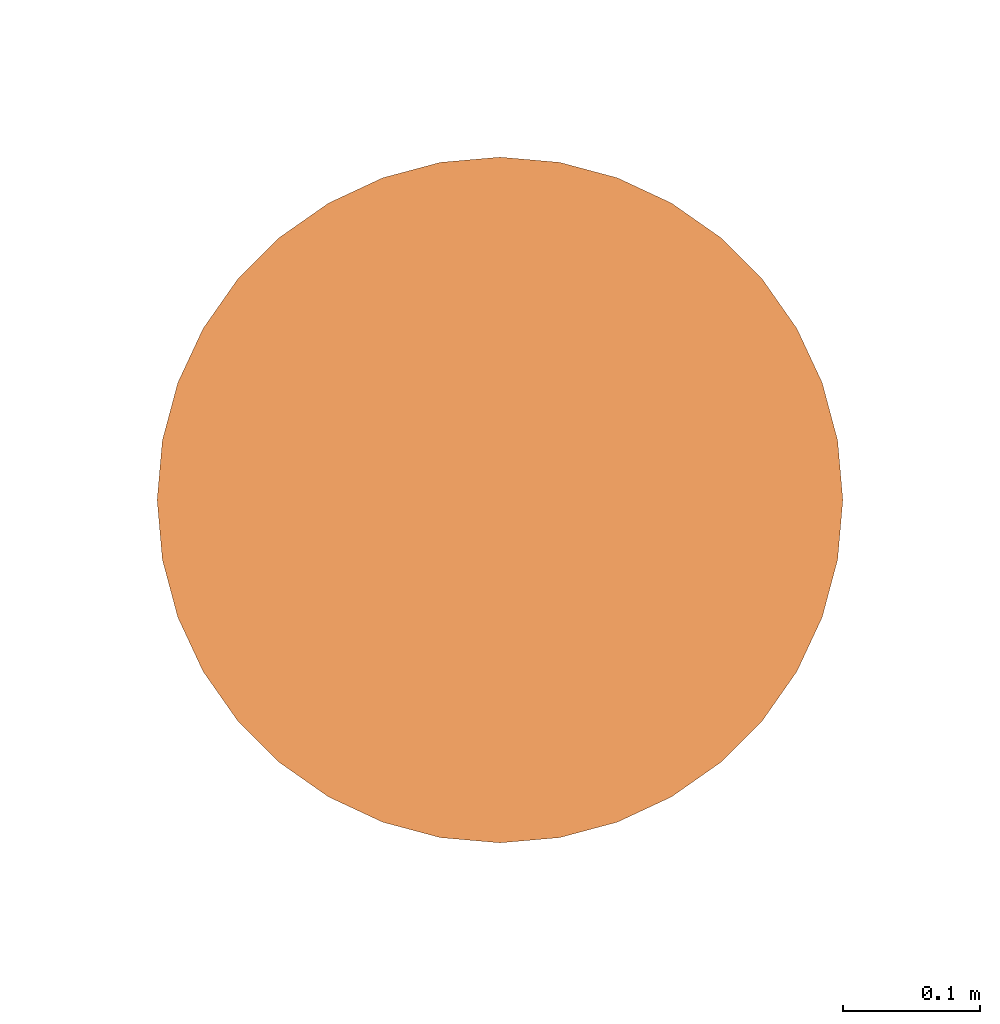
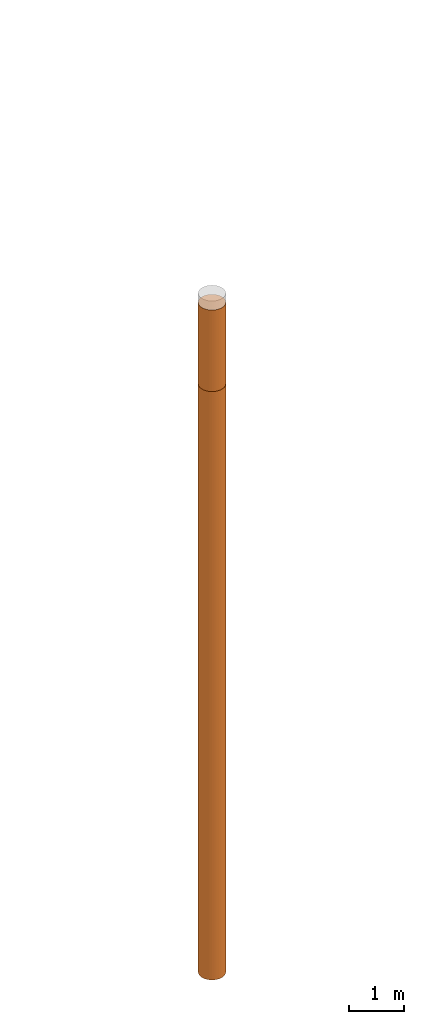
# One storey, part 1 of 8: 2 proxies.
"""IFC4 building model written with IfcOpenShell, lengths in metres."""

from ifc_helpers import new_model, entity, si_unit, converted_unit, frame, origin, place, context, subcontext, project, spatial, faceted_brep, material, element, save


model = new_model("IFC4")

# Units and contexts
model_context = context("Model", 3, precision=1e-05, world=origin())
body_context = subcontext(model_context, "Body", "Model", "MODEL_VIEW")
ifc_project = project(units=[si_unit("LENGTHUNIT", "METRE"), si_unit("AREAUNIT", "SQUARE_METRE"), si_unit("VOLUMEUNIT", "CUBIC_METRE"), converted_unit("PLANEANGLEUNIT", "DEGREE", entity("IfcPlaneAngleMeasure", 0.0174532925199433), si_unit("PLANEANGLEUNIT", "RADIAN"), dimensions=[0, 0, 0, 0, 0, 0, 0])], contexts=[model_context])

# Site, building, storey
site_placement = place(None, origin())
site = spatial("IfcSite", under=ifc_project, at=site_placement, CompositionType="ELEMENT")
building_placement = place(site_placement, origin())
building = spatial("IfcBuilding", under=site, at=building_placement, Name="Demo", CompositionType="ELEMENT")
storey_placement = place(building_placement, origin())
storey = spatial("IfcBuildingStorey", under=building, at=storey_placement, Name="Boden", CompositionType="ELEMENT", Elevation=0.0)

# Proxies
ifc_material_1 = material()
proxy_1_placement = place(storey_placement, frame((2.57, 5.87, -1.9)))
element("IfcBuildingElementProxy", 1, at=proxy_1_placement, inside=storey, material=ifc_material_1, Name="KB-01_Sand", PredefinedType="USERDEFINED", context=body_context, shape_type="Brep", body=[
    faceted_brep([(0.4962019382530516, 0.2934120444167338, 1.8), (0.5, 0.25, 1.8), (0.496201938253052, 0.2065879555832671, 1.8), (0.4849231551964772, 0.1644949641685826, 1.8), (0.4665063509461097, 0.125, 1.8), (0.4415111107797448, 0.08930309757836494, 1.8), (0.4106969024216351, 0.05848888922025526, 1.8), (0.375, 0.0334936490538903, 1.8), (0.3355050358314174, 0.01507684480352327, 1.8), (0.2934120444167325, 0.003798061746948406, 1.8), (0.25, 0.0, 1.8), (0.2065879555832676, 0.003798061746948406, 1.8), (0.164494964168583, 0.01507684480352327, 1.8), (0.125, 0.0334936490538903, 1.8), (0.0893030975783654, 0.05848888922025526, 1.8), (0.05848888922025572, 0.08930309757836494, 1.8), (0.0334936490538903, 0.125, 1.8), (0.01507684480352327, 0.1644949641685826, 1.8), (0.003798061746947951, 0.2065879555832671, 1.8), (0.0, 0.25, 1.8), (0.003798061746947951, 0.293412044416732, 1.8), (0.01507684480352282, 0.3355050358314166, 1.8), (0.03349364905388984, 0.375, 1.8), (0.05848888922025526, 0.4106969024216342, 1.8), (0.08930309757836494, 0.4415111107797439, 1.8), (0.1249999999999995, 0.4665063509461097, 1.8), (0.1644949641685821, 0.4849231551964767, 1.8), (0.2065879555832667, 0.4962019382530516, 1.8), (0.2499999999999991, 0.5, 1.8), (0.293412044416732, 0.4962019382530525, 1.8), (0.3355050358314166, 0.4849231551964777, 1.8), (0.3749999999999991, 0.4665063509461097, 1.8), (0.4106969024216342, 0.4415111107797448, 1.8), (0.4415111107797439, 0.410696902421636, 1.8), (0.4665063509461093, 0.3750000000000009, 1.8), (0.4849231551964767, 0.3355050358314184, 1.8), (0.5, 0.25, 0.0), (0.4962019382530516, 0.2934120444167338, 0.0), (0.4849231551964767, 0.3355050358314184, 0.0), (0.4665063509461093, 0.3750000000000009, 0.0), (0.4415111107797439, 0.4106969024216351, 0.0), (0.4106969024216342, 0.4415111107797448, 0.0), (0.3749999999999991, 0.4665063509461097, 0.0), (0.3355050358314166, 0.4849231551964767, 0.0), (0.293412044416732, 0.4962019382530516, 0.0), (0.2499999999999991, 0.5, 0.0), (0.2065879555832667, 0.4962019382530516, 0.0), (0.1644949641685821, 0.4849231551964767, 0.0), (0.1249999999999995, 0.4665063509461088, 0.0), (0.08930309757836494, 0.4415111107797439, 0.0), (0.05848888922025526, 0.4106969024216342, 0.0), (0.03349364905388984, 0.3749999999999991, 0.0), (0.01507684480352282, 0.3355050358314166, 0.0), (0.003798061746947951, 0.293412044416732, 0.0), (0.0, 0.2499999999999991, 0.0), (0.003798061746947951, 0.2065879555832671, 0.0), (0.01507684480352327, 0.1644949641685826, 0.0), (0.0334936490538903, 0.125, 0.0), (0.05848888922025572, 0.08930309757836494, 0.0), (0.0893030975783654, 0.05848888922025526, 0.0), (0.125, 0.0334936490538903, 0.0), (0.164494964168583, 0.01507684480352236, 0.0), (0.2065879555832676, 0.003798061746947497, 0.0), (0.25, 0.0, 0.0), (0.2934120444167325, 0.003798061746947497, 0.0), (0.3355050358314174, 0.01507684480352236, 0.0), (0.375, 0.0334936490538903, 0.0), (0.4106969024216351, 0.05848888922025526, 0.0), (0.4415111107797448, 0.08930309757836494, 0.0), (0.4665063509461097, 0.125, 0.0), (0.4849231551964772, 0.1644949641685826, 0.0), (0.496201938253052, 0.2065879555832671, 0.0), (0.5, 0.25, 1.8), (0.4962019382530516, 0.2934120444167338, 1.8), (0.4962019382530516, 0.2934120444167338, 0.0), (0.5, 0.25, 0.0), (0.496201938253052, 0.2065879555832671, 1.8), (0.5, 0.25, 1.8), (0.5, 0.25, 0.0), (0.496201938253052, 0.2065879555832671, 0.0), (0.4849231551964772, 0.1644949641685826, 1.8), (0.496201938253052, 0.2065879555832671, 1.8), (0.496201938253052, 0.2065879555832671, 0.0), (0.4849231551964772, 0.1644949641685826, 0.0), (0.4665063509461097, 0.125, 1.8), (0.4849231551964772, 0.1644949641685826, 1.8), (0.4849231551964772, 0.1644949641685826, 0.0), (0.4665063509461097, 0.125, 0.0), (0.4415111107797448, 0.08930309757836494, 1.8), (0.4665063509461097, 0.125, 1.8), (0.4665063509461097, 0.125, 0.0), (0.4415111107797448, 0.08930309757836494, 0.0), (0.4106969024216351, 0.05848888922025526, 1.8), (0.4415111107797448, 0.08930309757836494, 1.8), (0.4415111107797448, 0.08930309757836494, 0.0), (0.4106969024216351, 0.05848888922025526, 0.0), (0.375, 0.0334936490538903, 1.8), (0.4106969024216351, 0.05848888922025526, 1.8), (0.4106969024216351, 0.05848888922025526, 0.0), (0.375, 0.0334936490538903, 0.0), (0.3355050358314174, 0.01507684480352327, 1.8), (0.375, 0.0334936490538903, 1.8), (0.375, 0.0334936490538903, 0.0), (0.3355050358314174, 0.01507684480352236, 0.0), (0.2934120444167325, 0.003798061746948406, 1.8), (0.3355050358314174, 0.01507684480352327, 1.8), (0.3355050358314174, 0.01507684480352236, 0.0), (0.2934120444167325, 0.003798061746947497, 0.0), (0.25, 0.0, 1.8), (0.2934120444167325, 0.003798061746948406, 1.8), (0.2934120444167325, 0.003798061746947497, 0.0), (0.25, 0.0, 0.0), (0.2065879555832676, 0.003798061746948406, 1.8), (0.25, 0.0, 1.8), (0.25, 0.0, 0.0), (0.2065879555832676, 0.003798061746947497, 0.0), (0.164494964168583, 0.01507684480352327, 1.8), (0.2065879555832676, 0.003798061746948406, 1.8), (0.2065879555832676, 0.003798061746947497, 0.0), (0.164494964168583, 0.01507684480352236, 0.0), (0.125, 0.0334936490538903, 1.8), (0.164494964168583, 0.01507684480352327, 1.8), (0.164494964168583, 0.01507684480352236, 0.0), (0.125, 0.0334936490538903, 0.0), (0.0893030975783654, 0.05848888922025526, 1.8), (0.125, 0.0334936490538903, 1.8), (0.125, 0.0334936490538903, 0.0), (0.0893030975783654, 0.05848888922025526, 0.0), (0.05848888922025572, 0.08930309757836494, 1.8), (0.0893030975783654, 0.05848888922025526, 1.8), (0.0893030975783654, 0.05848888922025526, 0.0), (0.05848888922025572, 0.08930309757836494, 0.0), (0.0334936490538903, 0.125, 1.8), (0.05848888922025572, 0.08930309757836494, 1.8), (0.05848888922025572, 0.08930309757836494, 0.0), (0.0334936490538903, 0.125, 0.0), (0.01507684480352327, 0.1644949641685826, 1.8), (0.0334936490538903, 0.125, 1.8), (0.0334936490538903, 0.125, 0.0), (0.01507684480352327, 0.1644949641685826, 0.0), (0.003798061746947951, 0.2065879555832671, 1.8), (0.01507684480352327, 0.1644949641685826, 1.8), (0.01507684480352327, 0.1644949641685826, 0.0), (0.003798061746947951, 0.2065879555832671, 0.0), (0.0, 0.25, 1.8), (0.003798061746947951, 0.2065879555832671, 1.8), (0.003798061746947951, 0.2065879555832671, 0.0), (0.0, 0.2499999999999991, 0.0), (0.003798061746947951, 0.293412044416732, 1.8), (0.0, 0.25, 1.8), (0.0, 0.2499999999999991, 0.0), (0.003798061746947951, 0.293412044416732, 0.0), (0.01507684480352282, 0.3355050358314166, 1.8), (0.003798061746947951, 0.293412044416732, 1.8), (0.003798061746947951, 0.293412044416732, 0.0), (0.01507684480352282, 0.3355050358314166, 0.0), (0.03349364905388984, 0.375, 1.8), (0.01507684480352282, 0.3355050358314166, 1.8), (0.01507684480352282, 0.3355050358314166, 0.0), (0.03349364905388984, 0.3749999999999991, 0.0), (0.05848888922025526, 0.4106969024216342, 1.8), (0.03349364905388984, 0.375, 1.8), (0.03349364905388984, 0.3749999999999991, 0.0), (0.05848888922025526, 0.4106969024216342, 0.0), (0.08930309757836494, 0.4415111107797439, 1.8), (0.05848888922025526, 0.4106969024216342, 1.8), (0.05848888922025526, 0.4106969024216342, 0.0), (0.08930309757836494, 0.4415111107797439, 0.0), (0.1249999999999995, 0.4665063509461097, 1.8), (0.08930309757836494, 0.4415111107797439, 1.8), (0.08930309757836494, 0.4415111107797439, 0.0), (0.1249999999999995, 0.4665063509461088, 0.0), (0.1644949641685821, 0.4849231551964767, 1.8), (0.1249999999999995, 0.4665063509461097, 1.8), (0.1249999999999995, 0.4665063509461088, 0.0), (0.1644949641685821, 0.4849231551964767, 0.0), (0.2065879555832667, 0.4962019382530516, 1.8), (0.1644949641685821, 0.4849231551964767, 1.8), (0.1644949641685821, 0.4849231551964767, 0.0), (0.2065879555832667, 0.4962019382530516, 0.0), (0.2499999999999991, 0.5, 1.8), (0.2065879555832667, 0.4962019382530516, 1.8), (0.2065879555832667, 0.4962019382530516, 0.0), (0.2499999999999991, 0.5, 0.0), (0.293412044416732, 0.4962019382530525, 1.8), (0.2499999999999991, 0.5, 1.8), (0.2499999999999991, 0.5, 0.0), (0.293412044416732, 0.4962019382530516, 0.0), (0.3355050358314166, 0.4849231551964777, 1.8), (0.293412044416732, 0.4962019382530525, 1.8), (0.293412044416732, 0.4962019382530516, 0.0), (0.3355050358314166, 0.4849231551964767, 0.0), (0.3749999999999991, 0.4665063509461097, 1.8), (0.3355050358314166, 0.4849231551964777, 1.8), (0.3355050358314166, 0.4849231551964767, 0.0), (0.3749999999999991, 0.4665063509461097, 0.0), (0.4106969024216342, 0.4415111107797448, 1.8), (0.3749999999999991, 0.4665063509461097, 1.8), (0.3749999999999991, 0.4665063509461097, 0.0), (0.4106969024216342, 0.4415111107797448, 0.0), (0.4415111107797439, 0.410696902421636, 1.8), (0.4106969024216342, 0.4415111107797448, 1.8), (0.4106969024216342, 0.4415111107797448, 0.0), (0.4415111107797439, 0.4106969024216351, 0.0), (0.4665063509461093, 0.3750000000000009, 1.8), (0.4415111107797439, 0.410696902421636, 1.8), (0.4415111107797439, 0.4106969024216351, 0.0), (0.4665063509461093, 0.3750000000000009, 0.0), (0.4849231551964767, 0.3355050358314184, 1.8), (0.4665063509461093, 0.3750000000000009, 1.8), (0.4665063509461093, 0.3750000000000009, 0.0), (0.4849231551964767, 0.3355050358314184, 0.0), (0.4962019382530516, 0.2934120444167338, 1.8), (0.4849231551964767, 0.3355050358314184, 1.8), (0.4849231551964767, 0.3355050358314184, 0.0), (0.4962019382530516, 0.2934120444167338, 0.0)], [[[0, 1, 2, 3, 4, 5, 6, 7, 8, 9, 10, 11, 12, 13, 14, 15, 16, 17, 18, 19, 20, 21, 22, 23, 24, 25, 26, 27, 28, 29, 30, 31, 32, 33, 34, 35]], [[36, 37, 38, 39, 40, 41, 42, 43, 44, 45, 46, 47, 48, 49, 50, 51, 52, 53, 54, 55, 56, 57, 58, 59, 60, 61, 62, 63, 64, 65, 66, 67, 68, 69, 70, 71]], [[72, 73, 74, 75]], [[76, 77, 78, 79]], [[80, 81, 82, 83]], [[84, 85, 86, 87]], [[88, 89, 90, 91]], [[92, 93, 94, 95]], [[96, 97, 98, 99]], [[100, 101, 102, 103]], [[104, 105, 106, 107]], [[108, 109, 110, 111]], [[112, 113, 114, 115]], [[116, 117, 118, 119]], [[120, 121, 122, 123]], [[124, 125, 126, 127]], [[128, 129, 130, 131]], [[132, 133, 134, 135]], [[136, 137, 138, 139]], [[140, 141, 142, 143]], [[144, 145, 146, 147]], [[148, 149, 150, 151]], [[152, 153, 154, 155]], [[156, 157, 158, 159]], [[160, 161, 162, 163]], [[164, 165, 166, 167]], [[168, 169, 170, 171]], [[172, 173, 174, 175]], [[176, 177, 178, 179]], [[180, 181, 182, 183]], [[184, 185, 186, 187]], [[188, 189, 190, 191]], [[192, 193, 194, 195]], [[196, 197, 198, 199]], [[200, 201, 202, 203]], [[204, 205, 206, 207]], [[208, 209, 210, 211]], [[212, 213, 214, 215]]], orient=[[False], [False], [False], [False], [False], [False], [False], [False], [False], [False], [False], [False], [False], [False], [False], [False], [False], [False], [False], [False], [False], [False], [False], [False], [False], [False], [False], [False], [False], [False], [False], [False], [False], [False], [False], [False], [False], [False]]),
])
ifc_material_2 = material()
proxy_2_placement = place(storey_placement, frame((2.57, 5.869999999999998, -14.9)))
element("IfcBuildingElementProxy", 2, at=proxy_2_placement, inside=storey, material=ifc_material_2, Name="KB-01_Kies", PredefinedType="USERDEFINED", context=body_context, shape_type="Brep", body=[
    faceted_brep([(0.4962019382530516, 0.2934120444167356, 13.0), (0.5, 0.2500000000000018, 13.0), (0.496201938253052, 0.2065879555832689, 13.0), (0.4849231551964772, 0.1644949641685844, 13.0), (0.4665063509461097, 0.1250000000000018, 13.0), (0.4415111107797448, 0.08930309757836676, 13.0), (0.4106969024216351, 0.05848888922025708, 13.0), (0.375, 0.03349364905389211, 13.0), (0.3355050358314174, 0.01507684480352509, 13.0), (0.2934120444167325, 0.003798061746950225, 13.0), (0.25, 1.818989403545857e-15, 13.0), (0.2065879555832676, 0.003798061746950225, 13.0), (0.164494964168583, 0.01507684480352509, 13.0), (0.125, 0.03349364905389211, 13.0), (0.0893030975783654, 0.05848888922025708, 13.0), (0.05848888922025572, 0.08930309757836676, 13.0), (0.0334936490538903, 0.1250000000000018, 13.0), (0.01507684480352327, 0.1644949641685844, 13.0), (0.003798061746947951, 0.2065879555832689, 13.0), (0.0, 0.2500000000000018, 13.0), (0.003798061746947951, 0.2934120444167338, 13.0), (0.01507684480352282, 0.3355050358314184, 13.0), (0.03349364905388984, 0.3750000000000018, 13.0), (0.05848888922025526, 0.410696902421636, 13.0), (0.08930309757836494, 0.4415111107797456, 13.0), (0.1249999999999995, 0.4665063509461115, 13.0), (0.1644949641685821, 0.4849231551964786, 13.0), (0.2065879555832667, 0.4962019382530534, 13.0), (0.2499999999999991, 0.5000000000000018, 13.0), (0.293412044416732, 0.4962019382530543, 13.0), (0.3355050358314166, 0.4849231551964795, 13.0), (0.3749999999999991, 0.4665063509461115, 13.0), (0.4106969024216342, 0.4415111107797466, 13.0), (0.4415111107797439, 0.4106969024216378, 13.0), (0.4665063509461093, 0.3750000000000027, 13.0), (0.4849231551964767, 0.3355050358314202, 13.0), (0.5, 0.25, 0.0), (0.4962019382530516, 0.2934120444167338, 0.0), (0.4849231551964767, 0.3355050358314184, 0.0), (0.4665063509461093, 0.3750000000000009, 0.0), (0.4415111107797439, 0.410696902421636, 0.0), (0.4106969024216342, 0.4415111107797456, 0.0), (0.3749999999999991, 0.4665063509461107, 0.0), (0.3355050358314166, 0.4849231551964777, 0.0), (0.293412044416732, 0.4962019382530525, 0.0), (0.2499999999999991, 0.5, 0.0), (0.2065879555832667, 0.4962019382530525, 0.0), (0.1644949641685821, 0.4849231551964767, 0.0), (0.1249999999999995, 0.4665063509461097, 0.0), (0.08930309757836494, 0.4415111107797448, 0.0), (0.05848888922025526, 0.4106969024216351, 0.0), (0.03349364905388984, 0.375, 0.0), (0.01507684480352282, 0.3355050358314166, 0.0), (0.003798061746947951, 0.293412044416732, 0.0), (0.0, 0.25, 0.0), (0.003798061746947951, 0.2065879555832671, 0.0), (0.01507684480352327, 0.1644949641685826, 0.0), (0.0334936490538903, 0.125, 0.0), (0.05848888922025572, 0.08930309757836494, 0.0), (0.0893030975783654, 0.05848888922025526, 0.0), (0.125, 0.0334936490538903, 0.0), (0.164494964168583, 0.01507684480352327, 0.0), (0.2065879555832676, 0.003798061746948406, 0.0), (0.25, 0.0, 0.0), (0.2934120444167325, 0.003798061746948406, 0.0), (0.3355050358314174, 0.01507684480352327, 0.0), (0.375, 0.0334936490538903, 0.0), (0.4106969024216351, 0.05848888922025617, 0.0), (0.4415111107797448, 0.08930309757836585, 0.0), (0.4665063509461097, 0.125, 0.0), (0.4849231551964772, 0.1644949641685835, 0.0), (0.496201938253052, 0.206587955583268, 0.0), (0.5, 0.2500000000000018, 13.0), (0.4962019382530516, 0.2934120444167356, 13.0), (0.4962019382530516, 0.2934120444167338, 0.0), (0.5, 0.25, 0.0), (0.496201938253052, 0.2065879555832689, 13.0), (0.5, 0.2500000000000018, 13.0), (0.5, 0.25, 0.0), (0.496201938253052, 0.206587955583268, 0.0), (0.4849231551964772, 0.1644949641685844, 13.0), (0.496201938253052, 0.2065879555832689, 13.0), (0.496201938253052, 0.206587955583268, 0.0), (0.4849231551964772, 0.1644949641685835, 0.0), (0.4665063509461097, 0.1250000000000018, 13.0), (0.4849231551964772, 0.1644949641685844, 13.0), (0.4849231551964772, 0.1644949641685835, 0.0), (0.4665063509461097, 0.125, 0.0), (0.4415111107797448, 0.08930309757836676, 13.0), (0.4665063509461097, 0.1250000000000018, 13.0), (0.4665063509461097, 0.125, 0.0), (0.4415111107797448, 0.08930309757836585, 0.0), (0.4106969024216351, 0.05848888922025708, 13.0), (0.4415111107797448, 0.08930309757836676, 13.0), (0.4415111107797448, 0.08930309757836585, 0.0), (0.4106969024216351, 0.05848888922025617, 0.0), (0.375, 0.03349364905389211, 13.0), (0.4106969024216351, 0.05848888922025708, 13.0), (0.4106969024216351, 0.05848888922025617, 0.0), (0.375, 0.0334936490538903, 0.0), (0.3355050358314174, 0.01507684480352509, 13.0), (0.375, 0.03349364905389211, 13.0), (0.375, 0.0334936490538903, 0.0), (0.3355050358314174, 0.01507684480352327, 0.0), (0.2934120444167325, 0.003798061746950225, 13.0), (0.3355050358314174, 0.01507684480352509, 13.0), (0.3355050358314174, 0.01507684480352327, 0.0), (0.2934120444167325, 0.003798061746948406, 0.0), (0.25, 1.818989403545857e-15, 13.0), (0.2934120444167325, 0.003798061746950225, 13.0), (0.2934120444167325, 0.003798061746948406, 0.0), (0.25, 0.0, 0.0), (0.2065879555832676, 0.003798061746950225, 13.0), (0.25, 1.818989403545857e-15, 13.0), (0.25, 0.0, 0.0), (0.2065879555832676, 0.003798061746948406, 0.0), (0.164494964168583, 0.01507684480352509, 13.0), (0.2065879555832676, 0.003798061746950225, 13.0), (0.2065879555832676, 0.003798061746948406, 0.0), (0.164494964168583, 0.01507684480352327, 0.0), (0.125, 0.03349364905389211, 13.0), (0.164494964168583, 0.01507684480352509, 13.0), (0.164494964168583, 0.01507684480352327, 0.0), (0.125, 0.0334936490538903, 0.0), (0.0893030975783654, 0.05848888922025708, 13.0), (0.125, 0.03349364905389211, 13.0), (0.125, 0.0334936490538903, 0.0), (0.0893030975783654, 0.05848888922025526, 0.0), (0.05848888922025572, 0.08930309757836676, 13.0), (0.0893030975783654, 0.05848888922025708, 13.0), (0.0893030975783654, 0.05848888922025526, 0.0), (0.05848888922025572, 0.08930309757836494, 0.0), (0.0334936490538903, 0.1250000000000018, 13.0), (0.05848888922025572, 0.08930309757836676, 13.0), (0.05848888922025572, 0.08930309757836494, 0.0), (0.0334936490538903, 0.125, 0.0), (0.01507684480352327, 0.1644949641685844, 13.0), (0.0334936490538903, 0.1250000000000018, 13.0), (0.0334936490538903, 0.125, 0.0), (0.01507684480352327, 0.1644949641685826, 0.0), (0.003798061746947951, 0.2065879555832689, 13.0), (0.01507684480352327, 0.1644949641685844, 13.0), (0.01507684480352327, 0.1644949641685826, 0.0), (0.003798061746947951, 0.2065879555832671, 0.0), (0.0, 0.2500000000000018, 13.0), (0.003798061746947951, 0.2065879555832689, 13.0), (0.003798061746947951, 0.2065879555832671, 0.0), (0.0, 0.25, 0.0), (0.003798061746947951, 0.2934120444167338, 13.0), (0.0, 0.2500000000000018, 13.0), (0.0, 0.25, 0.0), (0.003798061746947951, 0.293412044416732, 0.0), (0.01507684480352282, 0.3355050358314184, 13.0), (0.003798061746947951, 0.2934120444167338, 13.0), (0.003798061746947951, 0.293412044416732, 0.0), (0.01507684480352282, 0.3355050358314166, 0.0), (0.03349364905388984, 0.3750000000000018, 13.0), (0.01507684480352282, 0.3355050358314184, 13.0), (0.01507684480352282, 0.3355050358314166, 0.0), (0.03349364905388984, 0.375, 0.0), (0.05848888922025526, 0.410696902421636, 13.0), (0.03349364905388984, 0.3750000000000018, 13.0), (0.03349364905388984, 0.375, 0.0), (0.05848888922025526, 0.4106969024216351, 0.0), (0.08930309757836494, 0.4415111107797456, 13.0), (0.05848888922025526, 0.410696902421636, 13.0), (0.05848888922025526, 0.4106969024216351, 0.0), (0.08930309757836494, 0.4415111107797448, 0.0), (0.1249999999999995, 0.4665063509461115, 13.0), (0.08930309757836494, 0.4415111107797456, 13.0), (0.08930309757836494, 0.4415111107797448, 0.0), (0.1249999999999995, 0.4665063509461097, 0.0), (0.1644949641685821, 0.4849231551964786, 13.0), (0.1249999999999995, 0.4665063509461115, 13.0), (0.1249999999999995, 0.4665063509461097, 0.0), (0.1644949641685821, 0.4849231551964767, 0.0), (0.2065879555832667, 0.4962019382530534, 13.0), (0.1644949641685821, 0.4849231551964786, 13.0), (0.1644949641685821, 0.4849231551964767, 0.0), (0.2065879555832667, 0.4962019382530525, 0.0), (0.2499999999999991, 0.5000000000000018, 13.0), (0.2065879555832667, 0.4962019382530534, 13.0), (0.2065879555832667, 0.4962019382530525, 0.0), (0.2499999999999991, 0.5, 0.0), (0.293412044416732, 0.4962019382530543, 13.0), (0.2499999999999991, 0.5000000000000018, 13.0), (0.2499999999999991, 0.5, 0.0), (0.293412044416732, 0.4962019382530525, 0.0), (0.3355050358314166, 0.4849231551964795, 13.0), (0.293412044416732, 0.4962019382530543, 13.0), (0.293412044416732, 0.4962019382530525, 0.0), (0.3355050358314166, 0.4849231551964777, 0.0), (0.3749999999999991, 0.4665063509461115, 13.0), (0.3355050358314166, 0.4849231551964795, 13.0), (0.3355050358314166, 0.4849231551964777, 0.0), (0.3749999999999991, 0.4665063509461107, 0.0), (0.4106969024216342, 0.4415111107797466, 13.0), (0.3749999999999991, 0.4665063509461115, 13.0), (0.3749999999999991, 0.4665063509461107, 0.0), (0.4106969024216342, 0.4415111107797456, 0.0), (0.4415111107797439, 0.4106969024216378, 13.0), (0.4106969024216342, 0.4415111107797466, 13.0), (0.4106969024216342, 0.4415111107797456, 0.0), (0.4415111107797439, 0.410696902421636, 0.0), (0.4665063509461093, 0.3750000000000027, 13.0), (0.4415111107797439, 0.4106969024216378, 13.0), (0.4415111107797439, 0.410696902421636, 0.0), (0.4665063509461093, 0.3750000000000009, 0.0), (0.4849231551964767, 0.3355050358314202, 13.0), (0.4665063509461093, 0.3750000000000027, 13.0), (0.4665063509461093, 0.3750000000000009, 0.0), (0.4849231551964767, 0.3355050358314184, 0.0), (0.4962019382530516, 0.2934120444167356, 13.0), (0.4849231551964767, 0.3355050358314202, 13.0), (0.4849231551964767, 0.3355050358314184, 0.0), (0.4962019382530516, 0.2934120444167338, 0.0)], [[[0, 1, 2, 3, 4, 5, 6, 7, 8, 9, 10, 11, 12, 13, 14, 15, 16, 17, 18, 19, 20, 21, 22, 23, 24, 25, 26, 27, 28, 29, 30, 31, 32, 33, 34, 35]], [[36, 37, 38, 39, 40, 41, 42, 43, 44, 45, 46, 47, 48, 49, 50, 51, 52, 53, 54, 55, 56, 57, 58, 59, 60, 61, 62, 63, 64, 65, 66, 67, 68, 69, 70, 71]], [[72, 73, 74, 75]], [[76, 77, 78, 79]], [[80, 81, 82, 83]], [[84, 85, 86, 87]], [[88, 89, 90, 91]], [[92, 93, 94, 95]], [[96, 97, 98, 99]], [[100, 101, 102, 103]], [[104, 105, 106, 107]], [[108, 109, 110, 111]], [[112, 113, 114, 115]], [[116, 117, 118, 119]], [[120, 121, 122, 123]], [[124, 125, 126, 127]], [[128, 129, 130, 131]], [[132, 133, 134, 135]], [[136, 137, 138, 139]], [[140, 141, 142, 143]], [[144, 145, 146, 147]], [[148, 149, 150, 151]], [[152, 153, 154, 155]], [[156, 157, 158, 159]], [[160, 161, 162, 163]], [[164, 165, 166, 167]], [[168, 169, 170, 171]], [[172, 173, 174, 175]], [[176, 177, 178, 179]], [[180, 181, 182, 183]], [[184, 185, 186, 187]], [[188, 189, 190, 191]], [[192, 193, 194, 195]], [[196, 197, 198, 199]], [[200, 201, 202, 203]], [[204, 205, 206, 207]], [[208, 209, 210, 211]], [[212, 213, 214, 215]]], orient=[[False], [False], [False], [False], [False], [False], [False], [False], [False], [False], [False], [False], [False], [False], [False], [False], [False], [False], [False], [False], [False], [False], [False], [False], [False], [False], [False], [False], [False], [False], [False], [False], [False], [False], [False], [False], [False], [False]]),
])

save(model, "model.ifc")
